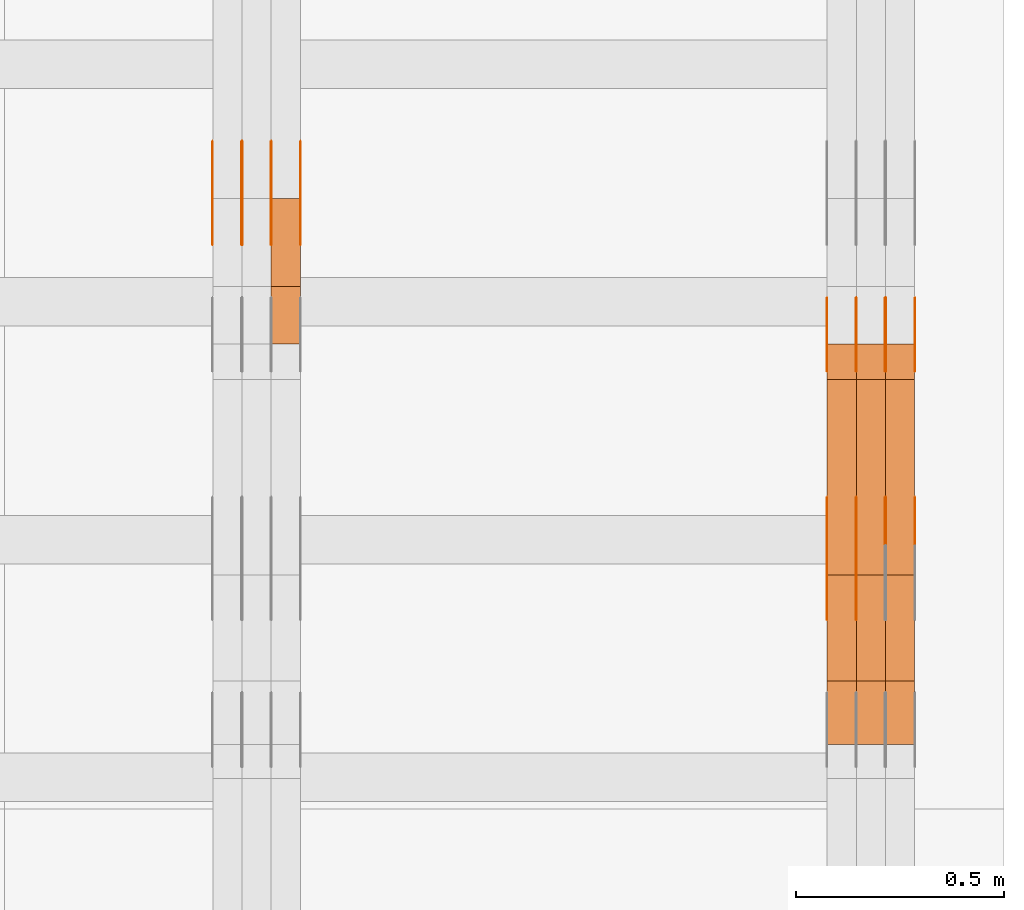
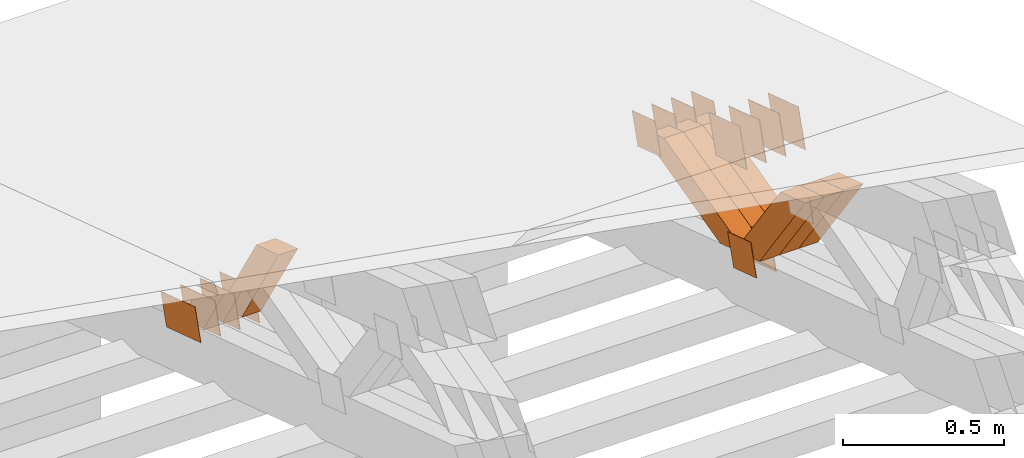
# One storey, part 374 of 385: 28 proxies.
"""IFC2X3 building model written with IfcOpenShell, lengths in millimetres."""

from ifc_helpers import new_model, entity, si_unit, converted_unit, derived_unit, direction, frame, origin, place, context, subcontext, project, spatial, polyline, outline, extrude, source, transform, mapped, material, type_object, type_shapes, element, save


model = new_model("IFC2X3")

# Units and contexts
model_context = context("Model", 3, precision=0.01, world=origin(), true_north=direction((6.12303176911189e-17, 1.0)))
body_context = subcontext(model_context, "Body", "Model", "MODEL_VIEW")
ifc_project = project(units=[si_unit("LENGTHUNIT", "METRE", prefix="MILLI"), si_unit("AREAUNIT", "SQUARE_METRE"), si_unit("VOLUMEUNIT", "CUBIC_METRE"), converted_unit("PLANEANGLEUNIT", "DEGREE", entity("IfcRatioMeasure", 0.0174532925199433), si_unit("PLANEANGLEUNIT", "RADIAN"), dimensions=[0, 0, 0, 0, 0, 0, 0]), si_unit("MASSUNIT", "GRAM", prefix="KILO"), derived_unit("MASSDENSITYUNIT", [(si_unit("MASSUNIT", "GRAM", prefix="KILO"), 1), (si_unit("LENGTHUNIT", "METRE"), -3)]), si_unit("TIMEUNIT", "SECOND"), si_unit("FREQUENCYUNIT", "HERTZ"), si_unit("THERMODYNAMICTEMPERATUREUNIT", "DEGREE_CELSIUS"), derived_unit("THERMALTRANSMITTANCEUNIT", [(si_unit("MASSUNIT", "GRAM", prefix="KILO"), 1), (si_unit("THERMODYNAMICTEMPERATUREUNIT", "KELVIN"), -1), (si_unit("TIMEUNIT", "SECOND"), -3)]), derived_unit("VOLUMETRICFLOWRATEUNIT", [(si_unit("LENGTHUNIT", "METRE"), 3), (si_unit("TIMEUNIT", "SECOND"), -1)]), si_unit("ELECTRICCURRENTUNIT", "AMPERE"), si_unit("ELECTRICVOLTAGEUNIT", "VOLT"), si_unit("POWERUNIT", "WATT"), si_unit("FORCEUNIT", "NEWTON", prefix="KILO"), si_unit("ILLUMINANCEUNIT", "LUX"), si_unit("LUMINOUSFLUXUNIT", "LUMEN"), si_unit("LUMINOUSINTENSITYUNIT", "CANDELA"), derived_unit("USERDEFINED", [(si_unit("MASSUNIT", "GRAM", prefix="KILO"), -1), (si_unit("LENGTHUNIT", "METRE"), -2), (si_unit("TIMEUNIT", "SECOND"), 3), (si_unit("LUMINOUSFLUXUNIT", "LUMEN"), 1)]), derived_unit("LINEARVELOCITYUNIT", [(si_unit("LENGTHUNIT", "METRE"), 1), (si_unit("TIMEUNIT", "SECOND"), -1)]), si_unit("PRESSUREUNIT", "PASCAL"), derived_unit("USERDEFINED", [(si_unit("LENGTHUNIT", "METRE"), -2), (si_unit("MASSUNIT", "GRAM", prefix="KILO"), 1), (si_unit("TIMEUNIT", "SECOND"), -2)])], contexts=[model_context])

# Site, building, storey
site_placement = place(None, origin())
site = spatial("IfcSite", under=ifc_project, at=site_placement, CompositionType="ELEMENT")
building_placement = place(site_placement, origin())
building = spatial("IfcBuilding", under=site, at=building_placement, CompositionType="ELEMENT")
storey_placement = place(building_placement, origin())
storey = spatial("IfcBuildingStorey", under=building, at=storey_placement, Name="Default", CompositionType="ELEMENT", Elevation=0.0)

# Proxies
ifc_material_1 = material(Name="IfcSurfaceStyle #608131")
building_element_proxy_type_1 = type_object("IfcBuildingElementProxyType", PredefinedType="NOTDEFINED", material=ifc_material_1)
shared_shape_1 = source(origin(), body_context, "Body", "SweptSolid", [
    extrude(outline(polyline([(-74.9998841352385, -59.9999554917014), (74.9998707133932, -59.9999554917014), (74.999874704788, 59.9999554917014), (-74.9998612829427, 59.9999554917014), (-74.9998841352385, -59.9999554917014)])), frame((75.0000802775471, 60.0000306612849, 0.0), z_axis=(0.0, 0.0, 1.0), x_axis=(-1.0, 0.0, 0.0)), (0.0, 0.0, 1.0), 1.29999999999999),
])
type_shapes(building_element_proxy_type_1, [shared_shape_1])
proxy_1_placement = place(building_placement, frame((49720.0, 24338.8869142613, 728.405515087805), z_axis=(-1.0, 0.0, 0.0), x_axis=(0.0, -0.951056516295124, 0.309016994375039)))
element("IfcBuildingElementProxy", 1, at=proxy_1_placement, inside=storey, type_object=building_element_proxy_type_1, material=ifc_material_1, context=body_context, shape_type="MappedRepresentation", body=[
    mapped(shared_shape_1, transform((0.0, 0.0, 0.0), scale=1.0)),
])
ifc_material_2 = material(Name="IfcSurfaceStyle #608074")
building_element_proxy_type_2 = type_object("IfcBuildingElementProxyType", PredefinedType="NOTDEFINED", material=ifc_material_2)
shared_shape_2 = source(origin(), body_context, "Body", "SweptSolid", [
    extrude(outline(polyline([(-74.9998841352385, -59.9999554917014), (74.9998707133932, -59.9999554917014), (74.999874704788, 59.9999554917014), (-74.9998612829427, 59.9999554917014), (-74.9998841352385, -59.9999554917014)])), frame((75.0000802775471, 60.0000306612849, 0.0), z_axis=(0.0, 0.0, 1.0), x_axis=(-1.0, 0.0, 0.0)), (0.0, 0.0, 1.0), 1.29999999999999),
])
type_shapes(building_element_proxy_type_2, [shared_shape_2])
proxy_2_placement = place(building_placement, frame((49721.3, 24338.8869142613, 728.405515087805), z_axis=(-1.0, 0.0, 0.0), x_axis=(0.0, -0.951056516295124, 0.309016994375039)))
element("IfcBuildingElementProxy", 2, at=proxy_2_placement, inside=storey, type_object=building_element_proxy_type_2, material=ifc_material_2, context=body_context, shape_type="MappedRepresentation", body=[
    mapped(shared_shape_2, transform((0.0, 0.0, 0.0), scale=1.0)),
])
ifc_material_3 = material(Name="IfcSurfaceStyle #608017")
building_element_proxy_type_3 = type_object("IfcBuildingElementProxyType", PredefinedType="NOTDEFINED", material=ifc_material_3)
shared_shape_3 = source(origin(), body_context, "Body", "SweptSolid", [
    extrude(outline(polyline([(-74.9998841352385, -59.9999554917014), (74.9998707133932, -59.9999554917014), (74.999874704788, 59.9999554917014), (-74.9998612829427, 59.9999554917014), (-74.9998841352385, -59.9999554917014)])), frame((75.0000802775471, 60.0000306612849, 0.0), z_axis=(0.0, 0.0, 1.0), x_axis=(-1.0, 0.0, 0.0)), (0.0, 0.0, 1.0), 1.29999999999999),
])
type_shapes(building_element_proxy_type_3, [shared_shape_3])
proxy_3_placement = place(building_placement, frame((49650.0, 24338.8869142613, 728.405515087805), z_axis=(-1.0, 0.0, 0.0), x_axis=(0.0, -0.951056516295124, 0.309016994375039)))
element("IfcBuildingElementProxy", 3, at=proxy_3_placement, inside=storey, type_object=building_element_proxy_type_3, material=ifc_material_3, context=body_context, shape_type="MappedRepresentation", body=[
    mapped(shared_shape_3, transform((0.0, 0.0, 0.0), scale=1.0)),
])
ifc_material_4 = material(Name="IfcSurfaceStyle #607618")
building_element_proxy_type_4 = type_object("IfcBuildingElementProxyType", PredefinedType="NOTDEFINED", material=ifc_material_4)
shared_shape_4 = source(origin(), body_context, "Body", "SweptSolid", [
    extrude(outline(polyline([(-75.0001163267648, -60.0000309352964), (75.0001029049313, -60.0000309352964), (75.0001068963143, 60.0000309352964), (-75.0000934744807, 60.0000309352964), (-75.0001163267648, -60.0000309352964)])), frame((75.0001143227305, 60.0000309352964, 0.0), z_axis=(0.0, 0.0, 1.0), x_axis=(-1.0, 0.0, 0.0)), (0.0, 0.0, 1.0), 1.3),
])
type_shapes(building_element_proxy_type_4, [shared_shape_4])
proxy_4_placement = place(building_placement, frame((49861.3, 24935.0160969462, 827.753587802763), z_axis=(-1.0, 0.0, 0.0), x_axis=(0.0, -0.951056516295154, 0.309016994374948)))
element("IfcBuildingElementProxy", 4, at=proxy_4_placement, inside=storey, type_object=building_element_proxy_type_4, material=ifc_material_4, context=body_context, shape_type="MappedRepresentation", body=[
    mapped(shared_shape_4, transform((0.0, 0.0, 0.0), scale=1.0)),
])
ifc_material_5 = material(Name="IfcSurfaceStyle #607561")
building_element_proxy_type_5 = type_object("IfcBuildingElementProxyType", PredefinedType="NOTDEFINED", material=ifc_material_5)
shared_shape_5 = source(origin(), body_context, "Body", "SweptSolid", [
    extrude(outline(polyline([(-75.0001163267648, -60.0000309352964), (75.0001029049313, -60.0000309352964), (75.0001068963143, 60.0000309352964), (-75.0000934744807, 60.0000309352964), (-75.0001163267648, -60.0000309352964)])), frame((75.0001143227305, 60.0000309352964, 0.0), z_axis=(0.0, 0.0, 1.0), x_axis=(-1.0, 0.0, 0.0)), (0.0, 0.0, 1.0), 1.3),
])
type_shapes(building_element_proxy_type_5, [shared_shape_5])
proxy_5_placement = place(building_placement, frame((49790.0, 24935.0160969462, 827.753587802763), z_axis=(-1.0, 0.0, 0.0), x_axis=(0.0, -0.951056516295154, 0.309016994374948)))
element("IfcBuildingElementProxy", 5, at=proxy_5_placement, inside=storey, type_object=building_element_proxy_type_5, material=ifc_material_5, context=body_context, shape_type="MappedRepresentation", body=[
    mapped(shared_shape_5, transform((0.0, 0.0, 0.0), scale=1.0)),
])
ifc_material_6 = material(Name="IfcSurfaceStyle #607504")
building_element_proxy_type_6 = type_object("IfcBuildingElementProxyType", PredefinedType="NOTDEFINED", material=ifc_material_6)
shared_shape_6 = source(origin(), body_context, "Body", "SweptSolid", [
    extrude(outline(polyline([(-75.0001163267648, -60.0000309352964), (75.0001029049313, -60.0000309352964), (75.0001068963143, 60.0000309352964), (-75.0000934744807, 60.0000309352964), (-75.0001163267648, -60.0000309352964)])), frame((75.0001143227305, 60.0000309352964, 0.0), z_axis=(0.0, 0.0, 1.0), x_axis=(-1.0, 0.0, 0.0)), (0.0, 0.0, 1.0), 1.3),
])
type_shapes(building_element_proxy_type_6, [shared_shape_6])
proxy_6_placement = place(building_placement, frame((49791.3, 24935.0160969462, 827.753587802763), z_axis=(-1.0, 0.0, 0.0), x_axis=(0.0, -0.951056516295154, 0.309016994374948)))
element("IfcBuildingElementProxy", 6, at=proxy_6_placement, inside=storey, type_object=building_element_proxy_type_6, material=ifc_material_6, context=body_context, shape_type="MappedRepresentation", body=[
    mapped(shared_shape_6, transform((0.0, 0.0, 0.0), scale=1.0)),
])
ifc_material_7 = material(Name="IfcSurfaceStyle #607447")
building_element_proxy_type_7 = type_object("IfcBuildingElementProxyType", PredefinedType="NOTDEFINED", material=ifc_material_7)
shared_shape_7 = source(origin(), body_context, "Body", "SweptSolid", [
    extrude(outline(polyline([(-75.0001163267648, -60.0000309352964), (75.0001029049313, -60.0000309352964), (75.0001068963143, 60.0000309352964), (-75.0000934744807, 60.0000309352964), (-75.0001163267648, -60.0000309352964)])), frame((75.0001143227305, 60.0000309352964, 0.0), z_axis=(0.0, 0.0, 1.0), x_axis=(-1.0, 0.0, 0.0)), (0.0, 0.0, 1.0), 1.29999999999999),
])
type_shapes(building_element_proxy_type_7, [shared_shape_7])
proxy_7_placement = place(building_placement, frame((49720.0, 24935.0160969462, 827.753587802763), z_axis=(-1.0, 0.0, 0.0), x_axis=(0.0, -0.951056516295154, 0.309016994374948)))
element("IfcBuildingElementProxy", 7, at=proxy_7_placement, inside=storey, type_object=building_element_proxy_type_7, material=ifc_material_7, context=body_context, shape_type="MappedRepresentation", body=[
    mapped(shared_shape_7, transform((0.0, 0.0, 0.0), scale=1.0)),
])
ifc_material_8 = material(Name="IfcSurfaceStyle #607390")
building_element_proxy_type_8 = type_object("IfcBuildingElementProxyType", PredefinedType="NOTDEFINED", material=ifc_material_8)
shared_shape_8 = source(origin(), body_context, "Body", "SweptSolid", [
    extrude(outline(polyline([(-75.0001163267648, -60.0000309352964), (75.0001029049313, -60.0000309352964), (75.0001068963143, 60.0000309352964), (-75.0000934744807, 60.0000309352964), (-75.0001163267648, -60.0000309352964)])), frame((75.0001143227305, 60.0000309352964, 0.0), z_axis=(0.0, 0.0, 1.0), x_axis=(-1.0, 0.0, 0.0)), (0.0, 0.0, 1.0), 1.29999999999999),
])
type_shapes(building_element_proxy_type_8, [shared_shape_8])
proxy_8_placement = place(building_placement, frame((49721.3, 24935.0160969462, 827.753587802763), z_axis=(-1.0, 0.0, 0.0), x_axis=(0.0, -0.951056516295154, 0.309016994374948)))
element("IfcBuildingElementProxy", 8, at=proxy_8_placement, inside=storey, type_object=building_element_proxy_type_8, material=ifc_material_8, context=body_context, shape_type="MappedRepresentation", body=[
    mapped(shared_shape_8, transform((0.0, 0.0, 0.0), scale=1.0)),
])
ifc_material_9 = material(Name="IfcSurfaceStyle #607333")
building_element_proxy_type_9 = type_object("IfcBuildingElementProxyType", PredefinedType="NOTDEFINED", material=ifc_material_9)
shared_shape_9 = source(origin(), body_context, "Body", "SweptSolid", [
    extrude(outline(polyline([(-75.0001163267648, -60.0000309352964), (75.0001029049313, -60.0000309352964), (75.0001068963143, 60.0000309352964), (-75.0000934744807, 60.0000309352964), (-75.0001163267648, -60.0000309352964)])), frame((75.0001143227305, 60.0000309352964, 0.0), z_axis=(0.0, 0.0, 1.0), x_axis=(-1.0, 0.0, 0.0)), (0.0, 0.0, 1.0), 1.29999999999999),
])
type_shapes(building_element_proxy_type_9, [shared_shape_9])
proxy_9_placement = place(building_placement, frame((49650.0, 24935.0160969462, 827.753587802763), z_axis=(-1.0, 0.0, 0.0), x_axis=(0.0, -0.951056516295154, 0.309016994374948)))
element("IfcBuildingElementProxy", 9, at=proxy_9_placement, inside=storey, type_object=building_element_proxy_type_9, material=ifc_material_9, context=body_context, shape_type="MappedRepresentation", body=[
    mapped(shared_shape_9, transform((0.0, 0.0, 0.0), scale=1.0)),
])
ifc_material_10 = material(Name="IfcSurfaceStyle #605224")
building_element_proxy_type_10 = type_object("IfcBuildingElementProxyType", PredefinedType="NOTDEFINED", material=ifc_material_10)
shared_shape_10 = source(origin(), body_context, "Body", "SweptSolid", [
    extrude(outline(polyline([(-100.000009625089, -72.0000630699202), (100.000090167682, -72.0000630699202), (100.000009625089, 72.0000630699202), (-100.000090167682, 72.0000630699202), (-100.000009625089, -72.0000630699202)])), frame((100.000090167682, 72.0000630699202, 0.0), z_axis=(0.0, 0.0, 1.0), x_axis=(-1.0, 0.0, 0.0)), (0.0, 0.0, 1.0), 1.3),
])
type_shapes(building_element_proxy_type_10, [shared_shape_10])
proxy_10_placement = place(building_placement, frame((49861.3, 24447.7695802369, 1088.58717039832), z_axis=(-1.0, 0.0, 0.0), x_axis=(0.0, -0.951056516295154, 0.309016994374948)))
element("IfcBuildingElementProxy", 10, at=proxy_10_placement, inside=storey, type_object=building_element_proxy_type_10, material=ifc_material_10, context=body_context, shape_type="MappedRepresentation", body=[
    mapped(shared_shape_10, transform((0.0, 0.0, 0.0), scale=1.0)),
])
ifc_material_11 = material(Name="IfcSurfaceStyle #605167")
building_element_proxy_type_11 = type_object("IfcBuildingElementProxyType", PredefinedType="NOTDEFINED", material=ifc_material_11)
shared_shape_11 = source(origin(), body_context, "Body", "SweptSolid", [
    extrude(outline(polyline([(-100.000009625089, -72.0000630699202), (100.000090167682, -72.0000630699202), (100.000009625089, 72.0000630699202), (-100.000090167682, 72.0000630699202), (-100.000009625089, -72.0000630699202)])), frame((100.000090167682, 72.0000630699202, 0.0), z_axis=(0.0, 0.0, 1.0), x_axis=(-1.0, 0.0, 0.0)), (0.0, 0.0, 1.0), 1.3),
])
type_shapes(building_element_proxy_type_11, [shared_shape_11])
proxy_11_placement = place(building_placement, frame((49790.0, 24447.7695802369, 1088.58717039832), z_axis=(-1.0, 0.0, 0.0), x_axis=(0.0, -0.951056516295154, 0.309016994374948)))
element("IfcBuildingElementProxy", 11, at=proxy_11_placement, inside=storey, type_object=building_element_proxy_type_11, material=ifc_material_11, context=body_context, shape_type="MappedRepresentation", body=[
    mapped(shared_shape_11, transform((0.0, 0.0, 0.0), scale=1.0)),
])
ifc_material_12 = material(Name="IfcSurfaceStyle #605110")
building_element_proxy_type_12 = type_object("IfcBuildingElementProxyType", PredefinedType="NOTDEFINED", material=ifc_material_12)
shared_shape_12 = source(origin(), body_context, "Body", "SweptSolid", [
    extrude(outline(polyline([(-100.000009625089, -72.0000630699202), (100.000090167682, -72.0000630699202), (100.000009625089, 72.0000630699202), (-100.000090167682, 72.0000630699202), (-100.000009625089, -72.0000630699202)])), frame((100.000090167682, 72.0000630699202, 0.0), z_axis=(0.0, 0.0, 1.0), x_axis=(-1.0, 0.0, 0.0)), (0.0, 0.0, 1.0), 1.3),
])
type_shapes(building_element_proxy_type_12, [shared_shape_12])
proxy_12_placement = place(building_placement, frame((49791.3, 24447.7695802369, 1088.58717039832), z_axis=(-1.0, 0.0, 0.0), x_axis=(0.0, -0.951056516295154, 0.309016994374948)))
element("IfcBuildingElementProxy", 12, at=proxy_12_placement, inside=storey, type_object=building_element_proxy_type_12, material=ifc_material_12, context=body_context, shape_type="MappedRepresentation", body=[
    mapped(shared_shape_12, transform((0.0, 0.0, 0.0), scale=1.0)),
])
ifc_material_13 = material(Name="IfcSurfaceStyle #605053")
building_element_proxy_type_13 = type_object("IfcBuildingElementProxyType", PredefinedType="NOTDEFINED", material=ifc_material_13)
shared_shape_13 = source(origin(), body_context, "Body", "SweptSolid", [
    extrude(outline(polyline([(-100.000009625089, -72.0000630699202), (100.000090167682, -72.0000630699202), (100.000009625089, 72.0000630699202), (-100.000090167682, 72.0000630699202), (-100.000009625089, -72.0000630699202)])), frame((100.000090167682, 72.0000630699202, 0.0), z_axis=(0.0, 0.0, 1.0), x_axis=(-1.0, 0.0, 0.0)), (0.0, 0.0, 1.0), 1.29999999999998),
])
type_shapes(building_element_proxy_type_13, [shared_shape_13])
proxy_13_placement = place(building_placement, frame((49720.0, 24447.7695802369, 1088.58717039832), z_axis=(-1.0, 0.0, 0.0), x_axis=(0.0, -0.951056516295154, 0.309016994374948)))
element("IfcBuildingElementProxy", 13, at=proxy_13_placement, inside=storey, type_object=building_element_proxy_type_13, material=ifc_material_13, context=body_context, shape_type="MappedRepresentation", body=[
    mapped(shared_shape_13, transform((0.0, 0.0, 0.0), scale=1.0)),
])
ifc_material_14 = material(Name="IfcSurfaceStyle #604996")
building_element_proxy_type_14 = type_object("IfcBuildingElementProxyType", PredefinedType="NOTDEFINED", material=ifc_material_14)
shared_shape_14 = source(origin(), body_context, "Body", "SweptSolid", [
    extrude(outline(polyline([(-100.000009625089, -72.0000630699202), (100.000090167682, -72.0000630699202), (100.000009625089, 72.0000630699202), (-100.000090167682, 72.0000630699202), (-100.000009625089, -72.0000630699202)])), frame((100.000090167682, 72.0000630699202, 0.0), z_axis=(0.0, 0.0, 1.0), x_axis=(-1.0, 0.0, 0.0)), (0.0, 0.0, 1.0), 1.29999999999998),
])
type_shapes(building_element_proxy_type_14, [shared_shape_14])
proxy_14_placement = place(building_placement, frame((49721.3, 24447.7695802369, 1088.58717039832), z_axis=(-1.0, 0.0, 0.0), x_axis=(0.0, -0.951056516295154, 0.309016994374948)))
element("IfcBuildingElementProxy", 14, at=proxy_14_placement, inside=storey, type_object=building_element_proxy_type_14, material=ifc_material_14, context=body_context, shape_type="MappedRepresentation", body=[
    mapped(shared_shape_14, transform((0.0, 0.0, 0.0), scale=1.0)),
])
ifc_material_15 = material(Name="IfcSurfaceStyle #604939")
building_element_proxy_type_15 = type_object("IfcBuildingElementProxyType", PredefinedType="NOTDEFINED", material=ifc_material_15)
shared_shape_15 = source(origin(), body_context, "Body", "SweptSolid", [
    extrude(outline(polyline([(-100.000009625089, -72.0000630699202), (100.000090167682, -72.0000630699202), (100.000009625089, 72.0000630699202), (-100.000090167682, 72.0000630699202), (-100.000009625089, -72.0000630699202)])), frame((100.000090167682, 72.0000630699202, 0.0), z_axis=(0.0, 0.0, 1.0), x_axis=(-1.0, 0.0, 0.0)), (0.0, 0.0, 1.0), 1.29999999999999),
])
type_shapes(building_element_proxy_type_15, [shared_shape_15])
proxy_15_placement = place(building_placement, frame((49650.0, 24447.7695802369, 1088.58717039832), z_axis=(-1.0, 0.0, 0.0), x_axis=(0.0, -0.951056516295154, 0.309016994374948)))
element("IfcBuildingElementProxy", 15, at=proxy_15_placement, inside=storey, type_object=building_element_proxy_type_15, material=ifc_material_15, context=body_context, shape_type="MappedRepresentation", body=[
    mapped(shared_shape_15, transform((0.0, 0.0, 0.0), scale=1.0)),
])
ifc_material_16 = material(Name="IfcSurfaceStyle #596026")
building_element_proxy_type_16 = type_object("IfcBuildingElementProxyType", Name="T2-W24 596024", PredefinedType="NOTDEFINED", material=ifc_material_16)
shared_shape_16 = source(origin(), body_context, "Body", "SweptSolid", [
    extrude(outline(polyline([(-215.642157779899, -47.4998772343114), (220.829928576248, -47.4998772343114), (202.182343865616, 6.34871490324596e-05), (137.545638852774, 47.4998454907369), (-344.915753514738, 47.4998454907369), (-215.642157779899, -47.4998772343114)])), frame((220.830079609702, 47.500154567531, 0.0), z_axis=(0.0, 0.0, 1.0), x_axis=(-1.0, 0.0, 0.0)), (0.0, 0.0, 1.0), 70.0),
])
type_shapes(building_element_proxy_type_16, [shared_shape_16])
proxy_16_placement = place(building_placement, frame((49860.0, 24227.7045444998, 781.019082122604), z_axis=(-1.0, 0.0, 0.0), x_axis=(0.0, -0.583381854128324, 0.812198012970851)))
element("IfcBuildingElementProxy", 16, at=proxy_16_placement, inside=storey, type_object=building_element_proxy_type_16, material=ifc_material_16, Name="T2-W24", context=body_context, shape_type="MappedRepresentation", body=[
    mapped(shared_shape_16, transform((0.0, 0.0, 0.0), scale=1.0)),
])
ifc_material_17 = material(Name="IfcSurfaceStyle #595960")
building_element_proxy_type_17 = type_object("IfcBuildingElementProxyType", Name="T2-W24 595958", PredefinedType="NOTDEFINED", material=ifc_material_17)
shared_shape_17 = source(origin(), body_context, "Body", "SweptSolid", [
    extrude(outline(polyline([(-215.642157779899, -47.4998772343114), (220.829928576248, -47.4998772343114), (202.182343865616, 6.34871490324596e-05), (137.545638852774, 47.4998454907369), (-344.915753514738, 47.4998454907369), (-215.642157779899, -47.4998772343114)])), frame((220.830079609702, 47.500154567531, 0.0), z_axis=(0.0, 0.0, 1.0), x_axis=(-1.0, 0.0, 0.0)), (0.0, 0.0, 1.0), 70.0),
])
type_shapes(building_element_proxy_type_17, [shared_shape_17])
proxy_17_placement = place(building_placement, frame((49790.0, 24227.7045444998, 781.019082122604), z_axis=(-1.0, 0.0, 0.0), x_axis=(0.0, -0.583381854128324, 0.812198012970851)))
element("IfcBuildingElementProxy", 17, at=proxy_17_placement, inside=storey, type_object=building_element_proxy_type_17, material=ifc_material_17, Name="T2-W24", context=body_context, shape_type="MappedRepresentation", body=[
    mapped(shared_shape_17, transform((0.0, 0.0, 0.0), scale=1.0)),
])
ifc_material_18 = material(Name="IfcSurfaceStyle #595894")
building_element_proxy_type_18 = type_object("IfcBuildingElementProxyType", Name="T2-W24 595892", PredefinedType="NOTDEFINED", material=ifc_material_18)
shared_shape_18 = source(origin(), body_context, "Body", "SweptSolid", [
    extrude(outline(polyline([(-215.642157779899, -47.4998772343114), (220.829928576248, -47.4998772343114), (202.182343865616, 6.34871490324596e-05), (137.545638852774, 47.4998454907369), (-344.915753514738, 47.4998454907369), (-215.642157779899, -47.4998772343114)])), frame((220.830079609702, 47.500154567531, 0.0), z_axis=(0.0, 0.0, 1.0), x_axis=(-1.0, 0.0, 0.0)), (0.0, 0.0, 1.0), 70.0),
])
type_shapes(building_element_proxy_type_18, [shared_shape_18])
proxy_18_placement = place(building_placement, frame((49720.0, 24227.7045444998, 781.019082122604), z_axis=(-1.0, 0.0, 0.0), x_axis=(0.0, -0.583381854128324, 0.812198012970851)))
element("IfcBuildingElementProxy", 18, at=proxy_18_placement, inside=storey, type_object=building_element_proxy_type_18, material=ifc_material_18, Name="T2-W24", context=body_context, shape_type="MappedRepresentation", body=[
    mapped(shared_shape_18, transform((0.0, 0.0, 0.0), scale=1.0)),
])
ifc_material_19 = material(Name="IfcSurfaceStyle #595630")
building_element_proxy_type_19 = type_object("IfcBuildingElementProxyType", Name="T2-W13 595628", PredefinedType="NOTDEFINED", material=ifc_material_19)
shared_shape_19 = source(origin(), body_context, "Body", "SweptSolid", [
    extrude(outline(polyline([(-384.339592151497, -47.5000055308246), (150.996422207105, -47.5000055308247), (226.265349299398, -4.29484466835994e-05), (240.878612116891, 47.500027005048), (-233.800791471897, 47.500027005048), (-384.339592151497, -47.5000055308246)])), frame((240.878612116891, 47.500027005048, 0.0), z_axis=(0.0, 0.0, 1.0), x_axis=(-1.0, 0.0, 0.0)), (0.0, 0.0, 1.0), 70.0),
])
type_shapes(building_element_proxy_type_19, [shared_shape_19])
proxy_19_placement = place(building_placement, frame((49860.0, 24884.765625, 885.749145507813), z_axis=(-1.0, 0.0, 0.0), x_axis=(0.0, -0.969210894563555, -0.246232089418326)))
element("IfcBuildingElementProxy", 19, at=proxy_19_placement, inside=storey, type_object=building_element_proxy_type_19, material=ifc_material_19, Name="T2-W13", context=body_context, shape_type="MappedRepresentation", body=[
    mapped(shared_shape_19, transform((0.0, 0.0, 0.0), scale=1.0)),
])
ifc_material_20 = material(Name="IfcSurfaceStyle #595564")
building_element_proxy_type_20 = type_object("IfcBuildingElementProxyType", Name="T2-W13 595562", PredefinedType="NOTDEFINED", material=ifc_material_20)
shared_shape_20 = source(origin(), body_context, "Body", "SweptSolid", [
    extrude(outline(polyline([(-384.339592151497, -47.5000055308246), (150.996422207105, -47.5000055308247), (226.265349299398, -4.29484466835994e-05), (240.878612116891, 47.500027005048), (-233.800791471897, 47.500027005048), (-384.339592151497, -47.5000055308246)])), frame((240.878612116891, 47.500027005048, 0.0), z_axis=(0.0, 0.0, 1.0), x_axis=(-1.0, 0.0, 0.0)), (0.0, 0.0, 1.0), 70.0),
])
type_shapes(building_element_proxy_type_20, [shared_shape_20])
proxy_20_placement = place(building_placement, frame((49790.0, 24884.765625, 885.749145507813), z_axis=(-1.0, 0.0, 0.0), x_axis=(0.0, -0.969210894563555, -0.246232089418326)))
element("IfcBuildingElementProxy", 20, at=proxy_20_placement, inside=storey, type_object=building_element_proxy_type_20, material=ifc_material_20, Name="T2-W13", context=body_context, shape_type="MappedRepresentation", body=[
    mapped(shared_shape_20, transform((0.0, 0.0, 0.0), scale=1.0)),
])
ifc_material_21 = material(Name="IfcSurfaceStyle #595498")
building_element_proxy_type_21 = type_object("IfcBuildingElementProxyType", Name="T2-W13 595496", PredefinedType="NOTDEFINED", material=ifc_material_21)
shared_shape_21 = source(origin(), body_context, "Body", "SweptSolid", [
    extrude(outline(polyline([(-384.339592151497, -47.5000055308246), (150.996422207105, -47.5000055308247), (226.265349299398, -4.29484466835994e-05), (240.878612116891, 47.500027005048), (-233.800791471897, 47.500027005048), (-384.339592151497, -47.5000055308246)])), frame((240.878612116891, 47.500027005048, 0.0), z_axis=(0.0, 0.0, 1.0), x_axis=(-1.0, 0.0, 0.0)), (0.0, 0.0, 1.0), 70.0),
])
type_shapes(building_element_proxy_type_21, [shared_shape_21])
proxy_21_placement = place(building_placement, frame((49720.0, 24884.765625, 885.749145507813), z_axis=(-1.0, 0.0, 0.0), x_axis=(0.0, -0.969210894563555, -0.246232089418326)))
element("IfcBuildingElementProxy", 21, at=proxy_21_placement, inside=storey, type_object=building_element_proxy_type_21, material=ifc_material_21, Name="T2-W13", context=body_context, shape_type="MappedRepresentation", body=[
    mapped(shared_shape_21, transform((0.0, 0.0, 0.0), scale=1.0)),
])
ifc_material_22 = material(Name="IfcSurfaceStyle #572844")
building_element_proxy_type_22 = type_object("IfcBuildingElementProxyType", PredefinedType="NOTDEFINED", material=ifc_material_22)
shared_shape_22 = source(origin(), body_context, "Body", "SweptSolid", [
    extrude(outline(polyline([(-112.50003853564, -60.0000121429077), (112.50002982902, -60.0000121429077), (112.500043250865, 60.0000121429077), (-112.500034544245, 60.0000121429077), (-112.50003853564, -60.0000121429077)])), frame((112.500056021398, 60.0000121429077, 0.0), z_axis=(0.0, 0.0, 1.0), x_axis=(-1.0, 0.0, 0.0)), (0.0, 0.0, 1.0), 1.3),
])
type_shapes(building_element_proxy_type_22, [shared_shape_22])
proxy_22_placement = place(building_placement, frame((48386.3, 25310.2182710495, 430.675738123044), z_axis=(-1.0, 0.0, 0.0), x_axis=(0.0, -0.951056516295124, 0.309016994375039)))
element("IfcBuildingElementProxy", 22, at=proxy_22_placement, inside=storey, type_object=building_element_proxy_type_22, material=ifc_material_22, context=body_context, shape_type="MappedRepresentation", body=[
    mapped(shared_shape_22, transform((0.0, 0.0, 0.0), scale=1.0)),
])
ifc_material_23 = material(Name="IfcSurfaceStyle #572787")
building_element_proxy_type_23 = type_object("IfcBuildingElementProxyType", PredefinedType="NOTDEFINED", material=ifc_material_23)
shared_shape_23 = source(origin(), body_context, "Body", "SweptSolid", [
    extrude(outline(polyline([(-112.50003853564, -60.0000121429077), (112.50002982902, -60.0000121429077), (112.500043250865, 60.0000121429077), (-112.500034544245, 60.0000121429077), (-112.50003853564, -60.0000121429077)])), frame((112.500056021398, 60.0000121429077, 0.0), z_axis=(0.0, 0.0, 1.0), x_axis=(-1.0, 0.0, 0.0)), (0.0, 0.0, 1.0), 1.3),
])
type_shapes(building_element_proxy_type_23, [shared_shape_23])
proxy_23_placement = place(building_placement, frame((48315.0, 25310.2182710495, 430.675738123044), z_axis=(-1.0, 0.0, 0.0), x_axis=(0.0, -0.951056516295124, 0.309016994375039)))
element("IfcBuildingElementProxy", 23, at=proxy_23_placement, inside=storey, type_object=building_element_proxy_type_23, material=ifc_material_23, context=body_context, shape_type="MappedRepresentation", body=[
    mapped(shared_shape_23, transform((0.0, 0.0, 0.0), scale=1.0)),
])
ifc_material_24 = material(Name="IfcSurfaceStyle #572730")
building_element_proxy_type_24 = type_object("IfcBuildingElementProxyType", PredefinedType="NOTDEFINED", material=ifc_material_24)
shared_shape_24 = source(origin(), body_context, "Body", "SweptSolid", [
    extrude(outline(polyline([(-112.50003853564, -60.0000121429077), (112.50002982902, -60.0000121429077), (112.500043250865, 60.0000121429077), (-112.500034544245, 60.0000121429077), (-112.50003853564, -60.0000121429077)])), frame((112.500056021398, 60.0000121429077, 0.0), z_axis=(0.0, 0.0, 1.0), x_axis=(-1.0, 0.0, 0.0)), (0.0, 0.0, 1.0), 1.3),
])
type_shapes(building_element_proxy_type_24, [shared_shape_24])
proxy_24_placement = place(building_placement, frame((48316.3, 25310.2182710495, 430.675738123044), z_axis=(-1.0, 0.0, 0.0), x_axis=(0.0, -0.951056516295124, 0.309016994375039)))
element("IfcBuildingElementProxy", 24, at=proxy_24_placement, inside=storey, type_object=building_element_proxy_type_24, material=ifc_material_24, context=body_context, shape_type="MappedRepresentation", body=[
    mapped(shared_shape_24, transform((0.0, 0.0, 0.0), scale=1.0)),
])
ifc_material_25 = material(Name="IfcSurfaceStyle #572673")
building_element_proxy_type_25 = type_object("IfcBuildingElementProxyType", PredefinedType="NOTDEFINED", material=ifc_material_25)
shared_shape_25 = source(origin(), body_context, "Body", "SweptSolid", [
    extrude(outline(polyline([(-112.50003853564, -60.0000121429077), (112.50002982902, -60.0000121429077), (112.500043250865, 60.0000121429077), (-112.500034544245, 60.0000121429077), (-112.50003853564, -60.0000121429077)])), frame((112.500056021398, 60.0000121429077, 0.0), z_axis=(0.0, 0.0, 1.0), x_axis=(-1.0, 0.0, 0.0)), (0.0, 0.0, 1.0), 1.29999999999998),
])
type_shapes(building_element_proxy_type_25, [shared_shape_25])
proxy_25_placement = place(building_placement, frame((48245.0, 25310.2182710495, 430.675738123044), z_axis=(-1.0, 0.0, 0.0), x_axis=(0.0, -0.951056516295124, 0.309016994375039)))
element("IfcBuildingElementProxy", 25, at=proxy_25_placement, inside=storey, type_object=building_element_proxy_type_25, material=ifc_material_25, context=body_context, shape_type="MappedRepresentation", body=[
    mapped(shared_shape_25, transform((0.0, 0.0, 0.0), scale=1.0)),
])
ifc_material_26 = material(Name="IfcSurfaceStyle #572616")
building_element_proxy_type_26 = type_object("IfcBuildingElementProxyType", PredefinedType="NOTDEFINED", material=ifc_material_26)
shared_shape_26 = source(origin(), body_context, "Body", "SweptSolid", [
    extrude(outline(polyline([(-112.50003853564, -60.0000121429077), (112.50002982902, -60.0000121429077), (112.500043250865, 60.0000121429077), (-112.500034544245, 60.0000121429077), (-112.50003853564, -60.0000121429077)])), frame((112.500056021398, 60.0000121429077, 0.0), z_axis=(0.0, 0.0, 1.0), x_axis=(-1.0, 0.0, 0.0)), (0.0, 0.0, 1.0), 1.29999999999998),
])
type_shapes(building_element_proxy_type_26, [shared_shape_26])
proxy_26_placement = place(building_placement, frame((48246.3, 25310.2182710495, 430.675738123044), z_axis=(-1.0, 0.0, 0.0), x_axis=(0.0, -0.951056516295124, 0.309016994375039)))
element("IfcBuildingElementProxy", 26, at=proxy_26_placement, inside=storey, type_object=building_element_proxy_type_26, material=ifc_material_26, context=body_context, shape_type="MappedRepresentation", body=[
    mapped(shared_shape_26, transform((0.0, 0.0, 0.0), scale=1.0)),
])
ifc_material_27 = material(Name="IfcSurfaceStyle #572559")
building_element_proxy_type_27 = type_object("IfcBuildingElementProxyType", PredefinedType="NOTDEFINED", material=ifc_material_27)
shared_shape_27 = source(origin(), body_context, "Body", "SweptSolid", [
    extrude(outline(polyline([(-112.50003853564, -60.0000121429077), (112.50002982902, -60.0000121429077), (112.500043250865, 60.0000121429077), (-112.500034544245, 60.0000121429077), (-112.50003853564, -60.0000121429077)])), frame((112.500056021398, 60.0000121429077, 0.0), z_axis=(0.0, 0.0, 1.0), x_axis=(-1.0, 0.0, 0.0)), (0.0, 0.0, 1.0), 1.29999999999999),
])
type_shapes(building_element_proxy_type_27, [shared_shape_27])
proxy_27_placement = place(building_placement, frame((48175.0, 25310.2182710495, 430.675738123044), z_axis=(-1.0, 0.0, 0.0), x_axis=(0.0, -0.951056516295124, 0.309016994375039)))
element("IfcBuildingElementProxy", 27, at=proxy_27_placement, inside=storey, type_object=building_element_proxy_type_27, material=ifc_material_27, context=body_context, shape_type="MappedRepresentation", body=[
    mapped(shared_shape_27, transform((0.0, 0.0, 0.0), scale=1.0)),
])
ifc_material_28 = material(Name="IfcSurfaceStyle #560802")
building_element_proxy_type_28 = type_object("IfcBuildingElementProxyType", Name="T1-W31 560800", PredefinedType="NOTDEFINED", material=ifc_material_28)
shared_shape_28 = source(origin(), body_context, "Body", "SweptSolid", [
    extrude(outline(polyline([(-201.245318299844, -47.5000121670808), (204.413774229459, -47.5000121670808), (182.034306640891, 5.35692244583164e-05), (126.70380769348, 47.4999853824686), (-311.906570263987, 47.4999853824686), (-201.245318299844, -47.5000121670808)])), frame((204.413774229459, 47.5002684334588, 0.0), z_axis=(0.0, 0.0, 1.0), x_axis=(-1.0, 0.0, 0.0)), (0.0, 0.0, 1.0), 70.0),
])
type_shapes(building_element_proxy_type_28, [shared_shape_28])
proxy_28_placement = place(building_placement, frame((48385.0, 25127.5652647985, 487.27008059185), z_axis=(-1.0, 0.0, 0.0), x_axis=(0.0, -0.520333970303023, 0.853962855953755)))
element("IfcBuildingElementProxy", 28, at=proxy_28_placement, inside=storey, type_object=building_element_proxy_type_28, material=ifc_material_28, Name="T1-W31", context=body_context, shape_type="MappedRepresentation", body=[
    mapped(shared_shape_28, transform((0.0, 0.0, 0.0), scale=1.0)),
])

save(model, "model.ifc")
